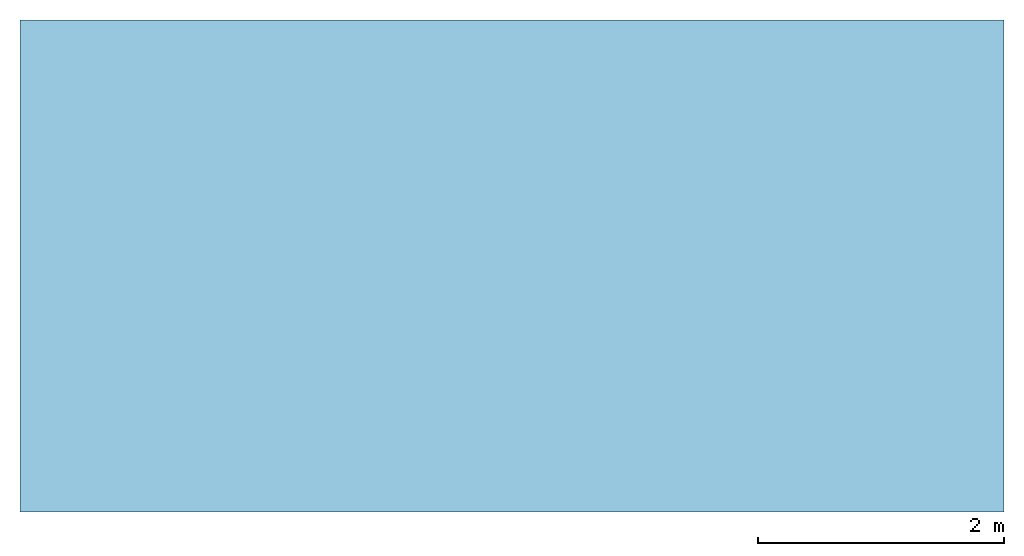
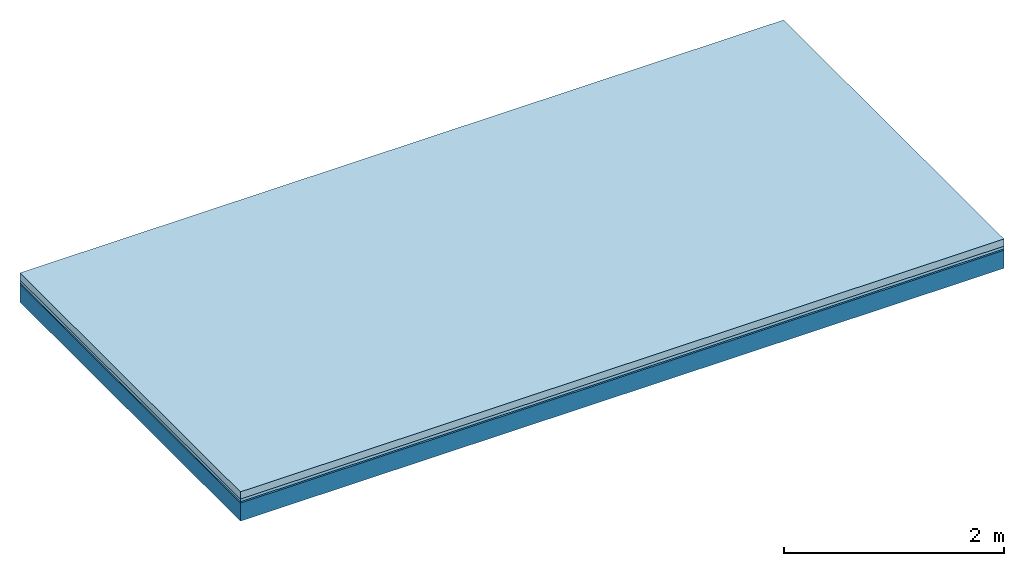
# One storey: 3 plates, 1 member, 1 element without a shape of its own.
"""IFC4 building model written with IfcOpenShell, lengths in metres."""

from ifc_helpers import new_model, si_unit, derived_unit, direction, frame, frame_2d, origin, origin_with_axes, place, context, project, spatial, rectangle, extrude, material, layer, layer_set, type_object, element, aggregate, save


model = new_model("IFC4")

# Units and contexts
plan_context = context("Plan", 3, precision=1e-05, world=origin(), true_north=direction((0.0, 1.0)))
model_context = context("Model", 3, precision=1e-05, world=origin(), true_north=direction((0.0, 1.0)))
ifc_project = project(units=[si_unit("LENGTHUNIT", "METRE"), derived_unit("SOUNDPRESSUREUNIT", [(si_unit("PRESSUREUNIT", "PASCAL", prefix="MICRO"), 0)]), si_unit("ENERGYUNIT", "JOULE", prefix="MEGA"), si_unit("MASSUNIT", "GRAM", prefix="KILO"), derived_unit("THERMALTRANSMITTANCEUNIT", [(si_unit("POWERUNIT", "WATT"), 1), (si_unit("AREAUNIT", "SQUARE_METRE"), -1), (si_unit("THERMODYNAMICTEMPERATUREUNIT", "KELVIN"), -1)]), derived_unit("AREADENSITYUNIT", [(si_unit("MASSUNIT", "GRAM", prefix="KILO"), 1), (si_unit("AREAUNIT", "SQUARE_METRE"), -1)]), derived_unit("USERDEFINED", [(si_unit("ENERGYUNIT", "JOULE", prefix="MEGA"), 1), (si_unit("AREAUNIT", "SQUARE_METRE"), -1)])], contexts=[plan_context, model_context])

# Site, building, storey
site = spatial("IfcSite", under=ifc_project)
building_placement = place(None, origin())
building = spatial("IfcBuilding", under=site, at=building_placement)
storey_placement = place(building_placement, origin())
storey = spatial("IfcBuildingStorey", under=building, at=storey_placement)

# Slab, member, plates
ifc_material_1 = material(Name="Cement screed", Category="04.006")
ifc_layer_1 = layer(ifc_material_1, 0.08, Name="On-material")
ifc_material_2 = material()
ifc_layer_2 = layer(ifc_material_2, 0.03, Name="Impact sound insulation")
ifc_material_3 = material(Category="03.007")
ifc_layer_3 = layer(ifc_material_3, 0.015, Name="on Supporting structure")
ifc_material_4 = material(Name="of the art")
ifc_layer_4 = layer(ifc_material_4, 0.0, Name="Bond")
ifc_layer_5 = layer(None, 0.2, Name="Supporting structure")
ifc_layer_set = layer_set([ifc_layer_1, ifc_layer_2, ifc_layer_3, ifc_layer_4, ifc_layer_5])
slab_type = type_object("IfcSlabType", Name="A0842", PredefinedType="NOTDEFINED", material=ifc_layer_set)
slab_placement = place(None, frame((0.0, 0.0, 0.0), z_axis=(0.0, 0.0, -1.0), x_axis=(1.0, 0.0, 0.0)))
slab = element("IfcSlab", 1, at=slab_placement, inside=storey, type_object=slab_type, material=ifc_layer_set, Name="Slab #1")
ifc_material_5 = material()
member_placement = place(slab_placement, origin())
member = element("IfcMember", 2, at=member_placement, material=ifc_material_5, Name="Supporting structure", context=plan_context, shape_type="SweptSolid", body=[
    extrude(rectangle(XDim=1.0, YDim=0.2, at=frame_2d((0.5, 0.1), x_axis=(1.0, 0.0))), frame((0.0, 4.0, 0.125), z_axis=(0.0, -1.0, 0.0), x_axis=(1.0, 0.0, 0.0)), (0.0, 0.0, 1.0), 4.0),
    extrude(rectangle(XDim=1.0, YDim=0.2, at=frame_2d((0.5, 0.1), x_axis=(1.0, 0.0))), frame((1.0, 4.0, 0.125), z_axis=(0.0, -1.0, 0.0), x_axis=(1.0, 0.0, 0.0)), (0.0, 0.0, 1.0), 4.0),
    extrude(rectangle(XDim=1.0, YDim=0.2, at=frame_2d((0.5, 0.1), x_axis=(1.0, 0.0))), frame((2.0, 4.0, 0.125), z_axis=(0.0, -1.0, 0.0), x_axis=(1.0, 0.0, 0.0)), (0.0, 0.0, 1.0), 4.0),
    extrude(rectangle(XDim=1.0, YDim=0.2, at=frame_2d((0.5, 0.1), x_axis=(1.0, 0.0))), frame((3.0, 4.0, 0.125), z_axis=(0.0, -1.0, 0.0), x_axis=(1.0, 0.0, 0.0)), (0.0, 0.0, 1.0), 4.0),
    extrude(rectangle(XDim=1.0, YDim=0.2, at=frame_2d((0.5, 0.1), x_axis=(1.0, 0.0))), frame((4.0, 4.0, 0.125), z_axis=(0.0, -1.0, 0.0), x_axis=(1.0, 0.0, 0.0)), (0.0, 0.0, 1.0), 4.0),
    extrude(rectangle(XDim=1.0, YDim=0.2, at=frame_2d((0.5, 0.1), x_axis=(1.0, 0.0))), frame((5.0, 4.0, 0.125), z_axis=(0.0, -1.0, 0.0), x_axis=(1.0, 0.0, 0.0)), (0.0, 0.0, 1.0), 4.0),
    extrude(rectangle(XDim=1.0, YDim=0.2, at=frame_2d((0.5, 0.1), x_axis=(1.0, 0.0))), frame((6.0, 4.0, 0.125), z_axis=(0.0, -1.0, 0.0), x_axis=(1.0, 0.0, 0.0)), (0.0, 0.0, 1.0), 4.0),
    extrude(rectangle(XDim=1.0, YDim=0.2, at=frame_2d((0.5, 0.1), x_axis=(1.0, 0.0))), frame((7.0, 4.0, 0.125), z_axis=(0.0, -1.0, 0.0), x_axis=(1.0, 0.0, 0.0)), (0.0, 0.0, 1.0), 4.0),
])
plate_1_placement = place(slab_placement, origin())
plate_1 = element("IfcPlate", 3, at=plate_1_placement, material=ifc_material_1, Name="On-material", context=plan_context, shape_type="SweptSolid", body=[
    extrude(rectangle(XDim=8.0, YDim=4.0, at=frame_2d((4.0, 2.0), x_axis=(1.0, 0.0))), origin_with_axes(), (0.0, 0.0, 1.0), 0.08),
])
plate_2_placement = place(slab_placement, origin())
plate_2 = element("IfcPlate", 4, at=plate_2_placement, material=ifc_material_2, Name="Impact sound insulation", context=plan_context, shape_type="SweptSolid", body=[
    extrude(rectangle(XDim=8.0, YDim=4.0, at=frame_2d((4.0, 2.0), x_axis=(1.0, 0.0))), frame((0.0, 0.0, 0.08), z_axis=(0.0, 0.0, 1.0), x_axis=(1.0, 0.0, 0.0)), (0.0, 0.0, 1.0), 0.03),
])
plate_3_placement = place(slab_placement, origin())
plate_3 = element("IfcPlate", 5, at=plate_3_placement, material=ifc_material_3, Name="on Supporting structure", context=plan_context, shape_type="SweptSolid", body=[
    extrude(rectangle(XDim=8.0, YDim=4.0, at=frame_2d((4.0, 2.0), x_axis=(1.0, 0.0))), frame((0.0, 0.0, 0.11), z_axis=(0.0, 0.0, 1.0), x_axis=(1.0, 0.0, 0.0)), (0.0, 0.0, 1.0), 0.015),
])
aggregate(slab, [plate_1, plate_2, plate_3, member])

save(model, "model.ifc")
